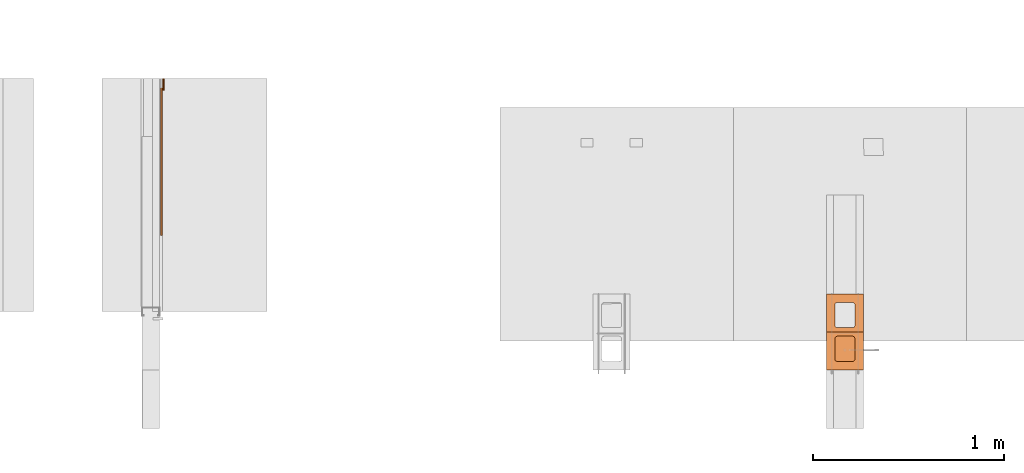
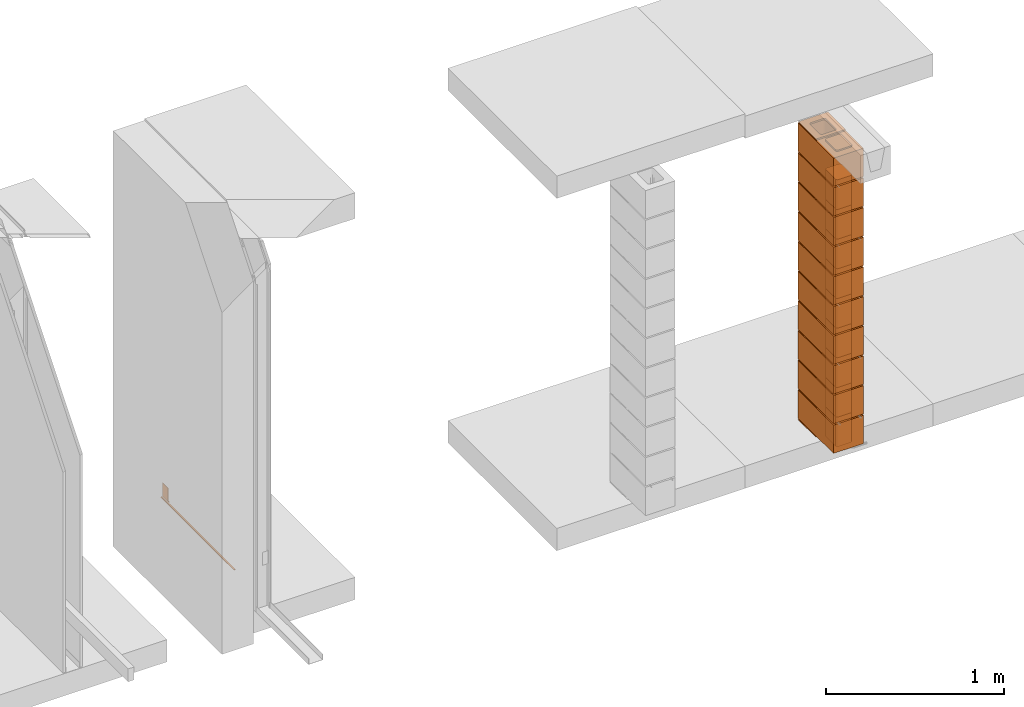
# One storey, part 44 of 64: 33 proxies.
"""IFC4 building model written with IfcOpenShell, lengths in feet."""

from ifc_helpers import new_model, entity, si_unit, converted_unit, frame, origin_with_axes, origin_2d_with_axis, place, context, subcontext, project, spatial, polyline, line, indexed_curve, outline, extrude, polygons, source, transform, mapped, material, type_object, type_shapes, element, save


model = new_model("IFC4")

# Units and contexts
model_context_1 = context("Model", 3, precision=1e-05, world=origin_with_axes())
plan_context = context("Plan", 2, precision=1e-05, world=origin_2d_with_axis())
model_context_2 = context("Model", 3, precision=1e-05, world=origin_with_axes())
context_of_model_1 = context(None, 3, precision=1e-05, world=origin_with_axes())
context_of_model_2 = context(None, 3, precision=1e-05, world=origin_with_axes())
body_context_1 = subcontext(model_context_1, "Body", "Model", "MODEL_VIEW")
body_context_2 = subcontext(model_context_2, "Body", "Model", "MODEL_VIEW")
ifc_project = project(units=[converted_unit("PLANEANGLEUNIT", "degree", entity("IfcReal", 0.0174532925199433), si_unit("PLANEANGLEUNIT", "RADIAN"), dimensions=[0, 0, 0, 0, 0, 0, 0]), converted_unit("AREAUNIT", "square foot", entity("IfcReal", 0.09290304), si_unit("AREAUNIT", "SQUARE_METRE"), dimensions=[2, 0, 0, 0, 0, 0, 0]), converted_unit("LENGTHUNIT", "foot", entity("IfcReal", 0.3048), si_unit("LENGTHUNIT", "METRE"), dimensions=[1, 0, 0, 0, 0, 0, 0]), converted_unit("VOLUMEUNIT", "cubic foot", entity("IfcReal", 0.0283168467116885), si_unit("VOLUMEUNIT", "CUBIC_METRE"), dimensions=[3, 0, 0, 0, 0, 0, 0])], contexts=[model_context_1, plan_context, context_of_model_1, context_of_model_2])

# Site, building, storey
site_placement = place(None, origin_with_axes())
site = spatial("IfcSite", under=ifc_project, at=site_placement)
building_placement = place(site_placement, origin_with_axes())
building = spatial("IfcBuilding", under=site, at=building_placement, Name="Building")
storey_placement = place(building_placement, origin_with_axes())
storey = spatial("IfcBuildingStorey", under=building, at=storey_placement, Name="Storey")

# Proxies
building_element_proxy_type_1 = type_object("IfcBuildingElementProxyType", PredefinedType="COMPLEX")
shared_shape_1 = source(origin_with_axes(), body_context_1, "Body", "SweptSolid", [
    extrude(outline(indexed_curve([(-0.317708352028228, -0.651041705777326), (0.317708352028228, -0.651041705777326), (0.317708352028228, 0.651041705777326), (-0.317708352028228, 0.651041705777326), (0.171874970041235, -0.114583378545255), (0.171874970041235, -0.463541685126898), (0.170455204220269, -0.47432586276938), (0.166292705639141, -0.484375053346939), (0.159671075466111, -0.493004429215208), (0.151041650709518, -0.499626059388238), (0.140992460131958, -0.50378860685769), (0.1302083313778, -0.505208323790332), (-0.1302083313778, -0.505208323790332), (-0.140992509020282, -0.50378860685769), (-0.151041699597842, -0.499626059388238), (-0.159671173242759, -0.493004429215208), (-0.166292705639141, -0.484375053346939), (-0.170455253108593, -0.47432586276938), (-0.171874970041235, -0.463541685126898), (-0.171874970041235, -0.114583378545255), (-0.170455253108593, -0.103799249791098), (-0.166292705639141, -0.0937500592135382), (-0.159671173242759, -0.0851205855686208), (-0.151041699597842, -0.0784989553955909), (-0.140992509020282, -0.0743364079261389), (-0.1302083313778, -0.0729166909934967), (0.1302083313778, -0.0729166909934967), (0.140992460131958, -0.0743364079261389), (0.151041650709518, -0.0784989553955909), (0.159671075466111, -0.0851205855686208), (0.166292705639141, -0.0937500592135382), (0.170455204220269, -0.103799249791098), (0.151041650709518, 0.0784989553955909), (0.140992460131958, 0.0743364079261389), (0.1302083313778, 0.0729166909934967), (-0.1302083313778, 0.0729166909934967), (-0.140992509020282, 0.0743364079261389), (-0.151041699597842, 0.0784989553955909), (-0.159671173242759, 0.0851204877919725), (-0.166292705639141, 0.0937499614368899), (-0.170455253108593, 0.10379915201445), (-0.171874970041235, 0.114583280768607), (-0.171874970041235, 0.46354158735025), (-0.170455253108593, 0.47432586276938), (-0.166292705639141, 0.484374955570291), (-0.159671173242759, 0.493004526991857), (-0.151041699597842, 0.499626059388238), (-0.140992509020282, 0.503788509081042), (-0.1302083313778, 0.505208323790332), (0.1302083313778, 0.505208323790332), (0.140992460131958, 0.503788509081042), (0.151041650709518, 0.499626059388238), (0.159671075466111, 0.493004526991857), (0.166292705639141, 0.484374955570291), (0.170455204220269, 0.47432586276938), (0.171874970041235, 0.46354158735025), (0.171874970041235, 0.114583280768607), (0.170455204220269, 0.10379915201445), (0.166292705639141, 0.0937499614368899), (0.159671075466111, 0.0851204877919725)], segments=[line(4, 3), line(3, 2), line(2, 1), line(1, 4)], self_intersect=False), holes=[indexed_curve([(-0.317708352028228, -0.651041705777326), (0.317708352028228, -0.651041705777326), (0.317708352028228, 0.651041705777326), (-0.317708352028228, 0.651041705777326), (0.171874970041235, -0.114583378545255), (0.171874970041235, -0.463541685126898), (0.170455204220269, -0.47432586276938), (0.166292705639141, -0.484375053346939), (0.159671075466111, -0.493004429215208), (0.151041650709518, -0.499626059388238), (0.140992460131958, -0.50378860685769), (0.1302083313778, -0.505208323790332), (-0.1302083313778, -0.505208323790332), (-0.140992509020282, -0.50378860685769), (-0.151041699597842, -0.499626059388238), (-0.159671173242759, -0.493004429215208), (-0.166292705639141, -0.484375053346939), (-0.170455253108593, -0.47432586276938), (-0.171874970041235, -0.463541685126898), (-0.171874970041235, -0.114583378545255), (-0.170455253108593, -0.103799249791098), (-0.166292705639141, -0.0937500592135382), (-0.159671173242759, -0.0851205855686208), (-0.151041699597842, -0.0784989553955909), (-0.140992509020282, -0.0743364079261389), (-0.1302083313778, -0.0729166909934967), (0.1302083313778, -0.0729166909934967), (0.140992460131958, -0.0743364079261389), (0.151041650709518, -0.0784989553955909), (0.159671075466111, -0.0851205855686208), (0.166292705639141, -0.0937500592135382), (0.170455204220269, -0.103799249791098), (0.151041650709518, 0.0784989553955909), (0.140992460131958, 0.0743364079261389), (0.1302083313778, 0.0729166909934967), (-0.1302083313778, 0.0729166909934967), (-0.140992509020282, 0.0743364079261389), (-0.151041699597842, 0.0784989553955909), (-0.159671173242759, 0.0851204877919725), (-0.166292705639141, 0.0937499614368899), (-0.170455253108593, 0.10379915201445), (-0.171874970041235, 0.114583280768607), (-0.171874970041235, 0.46354158735025), (-0.170455253108593, 0.47432586276938), (-0.166292705639141, 0.484374955570291), (-0.159671173242759, 0.493004526991857), (-0.151041699597842, 0.499626059388238), (-0.140992509020282, 0.503788509081042), (-0.1302083313778, 0.505208323790332), (0.1302083313778, 0.505208323790332), (0.140992460131958, 0.503788509081042), (0.151041650709518, 0.499626059388238), (0.159671075466111, 0.493004526991857), (0.166292705639141, 0.484374955570291), (0.170455204220269, 0.47432586276938), (0.171874970041235, 0.46354158735025), (0.171874970041235, 0.114583280768607), (0.170455204220269, 0.10379915201445), (0.166292705639141, 0.0937499614368899), (0.159671075466111, 0.0851204877919725)], segments=[line(20, 19), line(19, 18), line(18, 17), line(17, 16), line(16, 15), line(15, 14), line(14, 13), line(13, 12), line(12, 11), line(11, 10), line(10, 9), line(9, 8), line(8, 7), line(7, 6), line(6, 5), line(5, 32), line(32, 31), line(31, 30), line(30, 29), line(29, 28), line(28, 27), line(27, 26), line(26, 25), line(25, 24), line(24, 23), line(23, 22), line(22, 21), line(21, 20)], self_intersect=False), indexed_curve([(-0.317708352028228, -0.651041705777326), (0.317708352028228, -0.651041705777326), (0.317708352028228, 0.651041705777326), (-0.317708352028228, 0.651041705777326), (0.171874970041235, -0.114583378545255), (0.171874970041235, -0.463541685126898), (0.170455204220269, -0.47432586276938), (0.166292705639141, -0.484375053346939), (0.159671075466111, -0.493004429215208), (0.151041650709518, -0.499626059388238), (0.140992460131958, -0.50378860685769), (0.1302083313778, -0.505208323790332), (-0.1302083313778, -0.505208323790332), (-0.140992509020282, -0.50378860685769), (-0.151041699597842, -0.499626059388238), (-0.159671173242759, -0.493004429215208), (-0.166292705639141, -0.484375053346939), (-0.170455253108593, -0.47432586276938), (-0.171874970041235, -0.463541685126898), (-0.171874970041235, -0.114583378545255), (-0.170455253108593, -0.103799249791098), (-0.166292705639141, -0.0937500592135382), (-0.159671173242759, -0.0851205855686208), (-0.151041699597842, -0.0784989553955909), (-0.140992509020282, -0.0743364079261389), (-0.1302083313778, -0.0729166909934967), (0.1302083313778, -0.0729166909934967), (0.140992460131958, -0.0743364079261389), (0.151041650709518, -0.0784989553955909), (0.159671075466111, -0.0851205855686208), (0.166292705639141, -0.0937500592135382), (0.170455204220269, -0.103799249791098), (0.151041650709518, 0.0784989553955909), (0.140992460131958, 0.0743364079261389), (0.1302083313778, 0.0729166909934967), (-0.1302083313778, 0.0729166909934967), (-0.140992509020282, 0.0743364079261389), (-0.151041699597842, 0.0784989553955909), (-0.159671173242759, 0.0851204877919725), (-0.166292705639141, 0.0937499614368899), (-0.170455253108593, 0.10379915201445), (-0.171874970041235, 0.114583280768607), (-0.171874970041235, 0.46354158735025), (-0.170455253108593, 0.47432586276938), (-0.166292705639141, 0.484374955570291), (-0.159671173242759, 0.493004526991857), (-0.151041699597842, 0.499626059388238), (-0.140992509020282, 0.503788509081042), (-0.1302083313778, 0.505208323790332), (0.1302083313778, 0.505208323790332), (0.140992460131958, 0.503788509081042), (0.151041650709518, 0.499626059388238), (0.159671075466111, 0.493004526991857), (0.166292705639141, 0.484374955570291), (0.170455204220269, 0.47432586276938), (0.171874970041235, 0.46354158735025), (0.171874970041235, 0.114583280768607), (0.170455204220269, 0.10379915201445), (0.166292705639141, 0.0937499614368899), (0.159671075466111, 0.0851204877919725)], segments=[line(44, 43), line(43, 42), line(42, 41), line(41, 40), line(40, 39), line(39, 38), line(38, 37), line(37, 36), line(36, 35), line(35, 34), line(34, 33), line(33, 60), line(60, 59), line(59, 58), line(58, 57), line(57, 56), line(56, 55), line(55, 54), line(54, 53), line(53, 52), line(52, 51), line(51, 50), line(50, 49), line(49, 48), line(48, 47), line(47, 46), line(46, 45), line(45, 44)], self_intersect=False)]), frame((-0.651041608000678, -4.85461058579092e-05, 0.0), z_axis=(0.0, 0.0, 1.0), x_axis=(0.0, -1.0, 0.0)), (0.0, 0.0, 1.0), 0.635416715116103),
])
type_shapes(building_element_proxy_type_1, [shared_shape_1])
for number, where, z_axis, x_axis in (
    (1, (1419.09361511391, 2.30208313058368, 0.0312500003862178), (0.0, 0.0, 1.0), (7.54979012640431e-08, 0.999999999999997, 0.0)),
    (2, (1419.09361511391, 2.30208293503038, 0.697916710939933), (0.0, 0.0, 1.0), (1.94707183709394e-07, 0.999999999999981, 0.0)),
    (3, (1419.09361511391, 2.30208293503038, 1.36458341843813), (0.0, 0.0, 1.0), (1.94707183709394e-07, 0.999999999999981, 0.0)),
    (4, (1419.09361511391, 2.30208293503038, 2.03125022371297), (0.0, 0.0, 1.0), (1.94707183709394e-07, 0.999999999999981, 0.0)),
    (5, (1419.09361511391, 2.30208293503038, 2.69791683343452), (0.0, 0.0, 1.0), (1.94707183709394e-07, 0.999999999999981, 0.0)),
    (6, (1419.09361511391, 2.30208293503038, 3.36458324760277), (0.0, 0.0, 1.0), (1.94707183709394e-07, 0.999999999999981, 0.0)),
    (7, (1419.09361511391, 2.30208293503038, 4.03125024843091), (0.0, 0.0, 1.0), (1.94707183709394e-07, 0.999999999999981, 0.0)),
    (8, (1419.09361511391, 2.30208293503038, 4.69791685815245), (0.0, 0.0, 1.0), (1.94707183709394e-07, 0.999999999999981, 0.0)),
    (9, (1419.09361511391, 2.30208293503038, 5.364583467874), (0.0, 0.0, 1.0), (1.94707183709394e-07, 0.999999999999981, 0.0)),
    (10, (1419.09361511391, 2.30208293503038, 6.03125007759555), (0.0, 0.0, 1.0), (1.94707183709394e-07, 0.999999999999981, 0.0)),
):
    element("IfcBuildingElementProxy", number, at=place(storey_placement, frame(where, z_axis=z_axis, x_axis=x_axis)), inside=storey, type_object=building_element_proxy_type_1, context=body_context_1, shape_type="MappedRepresentation", body=[
        mapped(shared_shape_1, transform((0.0, 0.0, 0.0), x_axis=(1.0, 0.0, 0.0), y_axis=(0.0, 1.0, 0.0), z_axis=(0.0, 0.0, 1.0), scale=1.0)),
    ])
building_element_proxy_type_2 = type_object("IfcBuildingElementProxyType", PredefinedType="COMPLEX")
shared_shape_2 = source(origin_with_axes(), body_context_1, "Body", "Tessellation", [
    polygons([(-0.151415750384331, -0.151090204715729, -3.05552028123657e-09), (-9.77766489995702e-08, -0.31775689125061, -3.05552028123657e-09), (-0.158037275075912, -0.159719616174698, -3.05552028123657e-09), (-0.147253289818764, -0.14104101061821, -3.05552028123657e-09), (-0.145833477377892, -0.130256876349449, -3.05552028123657e-09), (-9.77766489995702e-08, 0.317659795284271, -3.05552028123657e-09), (-0.176715940237045, 0.170406714081764, -3.05552028123657e-09), (-0.187500223517418, 0.171826422214508, -3.05552028123657e-09), (-0.166666850447655, 0.16624416410923, -3.05552028123657e-09), (-0.158037275075912, 0.159622624516487, -3.05552028123657e-09), (-0.151415750384331, 0.150993153452873, -3.05552028123657e-09), (-0.147253289818764, 0.140943959355354, -3.05552028123657e-09), (-0.145833477377892, 0.13015978038311, -3.05552028123657e-09), (-0.57812511920929, 0.13015978038311, -3.05552028123657e-09), (-0.57812511920929, -0.130256876349449, -3.05552028123657e-09), (-0.57812511920929, 0.13015978038311, -0.0312500037252903), (-0.57812511920929, -0.130256876349449, -0.0312500037252903), (-0.187500223517418, 0.171826422214508, -0.0312500037252903), (-0.176715940237045, 0.170406714081764, -0.0312500037252903), (-0.151415750384331, 0.150993153452873, -0.0312500037252903), (-0.158037275075912, 0.159622624516487, -0.0312500037252903), (-0.166666850447655, 0.16624416410923, -0.0312500037252903), (-0.57254284620285, 0.150993153452873, -0.0312500037252903), (-0.57254284620285, 0.150993153452873, -3.05552028123657e-09), (-0.576705396175385, 0.140943959355354, -0.0312500037252903), (-0.576705396175385, 0.140943959355354, -3.05552028123657e-09), (-0.536458551883698, -0.171923518180847, -0.0312500037252903), (-0.536458551883698, -0.171923518180847, -3.05552028123657e-09), (-0.547242641448975, -0.170503750443459, -3.05552028123657e-09), (-0.547242641448975, -0.170503750443459, -0.0312500037252903), (-0.187500223517418, -0.171923518180847, -3.05552028123657e-09), (-0.187500223517418, -0.171923518180847, -0.0312500037252903), (-9.77766489995702e-08, 0.311301797628403, -0.0156250037252903), (-0.112195670604706, 0.311415702104568, -0.0178805738687515), (-9.77766489995702e-08, 0.312040388584137, -0.021326893940568), (-0.651041805744171, 0.312040388584137, -0.0099231107160449), (-0.525620222091675, 0.311301797628403, -0.0156250055879354), (-0.651041805744171, 0.311301797628403, -0.0156250037252903), (-0.14959417283535, 0.317659795284271, -3.05552028123657e-09), (-9.77766489995702e-08, 0.314207404851913, -0.00459759868681431), (-0.651041805744171, 0.317659795284271, -3.05552028123657e-09), (-0.501447737216949, 0.317659795284271, -3.05552028123657e-09), (-0.651041805744171, 0.314207404851913, -0.00459759868681431), (-9.77766489995702e-08, -0.314304441213608, -0.00459759868681431), (-0.112195670604706, -0.31151282787323, -0.0133694317191839), (-0.14959417283535, -0.31775689125061, -3.05552028123657e-09), (-9.77766489995702e-08, 0.314207404851913, -0.0266524087637663), (-0.14959417283535, 0.317659795284271, -0.0312500037252903), (-0.651041805744171, 0.314207404851913, -0.0266524087637663), (-0.501447856426239, 0.317659795284271, -0.0312500037252903), (-0.651041805744171, 0.317659795284271, -0.0312500037252903), (-9.77766489995702e-08, 0.317659795284271, -0.0312500037252903), (-9.77766489995702e-08, 0.312040388584137, -0.0099231107160449), (-0.651041805744171, 0.312040388584137, -0.021326893940568), (-0.14959417283535, -0.31775689125061, -0.0312500037252903), (-0.158037275075912, -0.159719616174698, -0.0312500037252903), (-9.77766489995702e-08, -0.31775689125061, -0.0312500037252903), (-0.151415750384331, -0.151090204715729, -0.0312500037252903), (-0.166666850447655, -0.166341260075569, -0.0312500037252903), (-0.176715940237045, -0.170503750443459, -0.0312500037252903), (-0.147253289818764, -0.14104101061821, -0.0312500037252903), (-0.145833477377892, -0.130256876349449, -0.0312500037252903), (-0.536458551883698, 0.171826422214508, -3.05552028123657e-09), (-9.77766489995702e-08, -0.314304441213608, -0.0266524087637663), (-0.651041805744171, -0.31775689125061, -0.0312500037252903), (-0.557291865348816, -0.166341260075569, -0.0312500037252903), (-0.565921306610107, -0.159719616174698, -0.0312500037252903), (-0.57254284620285, -0.151090204715729, -0.0312500037252903), (-0.576705396175385, -0.14104101061821, -0.0312500037252903), (-0.501447737216949, -0.31775689125061, -3.05552028123657e-09), (-0.547242641448975, 0.170406714081764, -3.05552028123657e-09), (-0.557291865348816, 0.16624416410923, -0.0312500037252903), (-0.547242641448975, 0.170406714081764, -0.0312500037252903), (-0.565921306610107, 0.159622624516487, -0.0312500037252903), (-9.77766489995702e-08, -0.311398863792419, -0.0156250037252903), (-9.77766489995702e-08, -0.312137424945831, -0.0099231107160449), (-0.651041805744171, -0.312137424945831, -0.021326893940568), (-0.525620222091675, -0.311398863792419, -0.0156250018626451), (-0.651041805744171, -0.311398863792419, -0.0156250037252903), (-0.501447737216949, -0.31775689125061, -0.0312500037252903), (-0.651041805744171, -0.314304441213608, -0.0266524087637663), (-0.651041805744171, -0.314304441213608, -0.00459759868681431), (-0.651041805744171, -0.31775689125061, -3.05552028123657e-09), (-9.77766489995702e-08, -0.312137424945831, -0.021326893940568), (-0.651041805744171, -0.312137424945831, -0.0099231107160449), (-0.145833477377892, 0.13015978038311, -0.0312500037252903), (-0.147253289818764, 0.140943959355354, -0.0312500037252903), (-0.536458551883698, 0.171826422214508, -0.0312500037252903), (-0.557291865348816, -0.166341260075569, -3.05552028123657e-09), (-0.176715940237045, -0.170503750443459, -3.05552028123657e-09), (-0.166666850447655, -0.166341260075569, -3.05552028123657e-09), (-0.576705396175385, -0.14104101061821, -3.05552028123657e-09), (-0.565921306610107, -0.159719616174698, -3.05552028123657e-09), (-0.57254284620285, -0.151090204715729, -3.05552028123657e-09), (-0.565921306610107, 0.159622624516487, -3.05552028123657e-09), (-0.557291865348816, 0.16624416410923, -3.05552028123657e-09)], [[[1, 3, 2]], [[4, 1, 2]], [[5, 4, 2]], [[6, 8, 7]], [[7, 9, 6]], [[9, 10, 6]], [[6, 10, 11]], [[6, 11, 12]], [[6, 12, 13]], [[6, 13, 5]], [[6, 5, 2]], [[20, 11, 10, 21]], [[63, 88, 18, 8]], [[7, 19, 22, 9]], [[95, 74, 72, 96]], [[71, 73, 88, 63]], [[61, 4, 5, 62]], [[17, 15, 92, 69]], [[23, 24, 26, 25]], [[33, 35, 34]], [[37, 38, 36]], [[6, 40, 39]], [[42, 43, 41]], [[44, 46, 45]], [[47, 48, 34]], [[50, 51, 49]], [[47, 52, 48]], [[53, 33, 34]], [[37, 36, 43]], [[37, 54, 38]], [[56, 57, 55]], [[58, 57, 56]], [[59, 56, 55]], [[60, 59, 55]], [[61, 57, 58]], [[62, 57, 61]], [[32, 60, 55]], [[47, 35, 84, 64]], [[52, 57, 62]], [[65, 81, 49, 51]], [[66, 30, 65]], [[67, 66, 65]], [[68, 67, 65]], [[69, 68, 65]], [[17, 69, 65]], [[27, 32, 55, 80]], [[41, 43, 82, 83]], [[51, 73, 72]], [[51, 72, 74]], [[51, 74, 23]], [[51, 23, 25]], [[16, 51, 25]], [[17, 51, 16]], [[65, 51, 17]], [[75, 76, 45]], [[78, 79, 77]], [[57, 64, 55]], [[80, 81, 65]], [[70, 83, 82]], [[44, 2, 46]], [[84, 75, 45]], [[78, 77, 81]], [[78, 85, 79]], [[3, 56, 59, 91]], [[14, 15, 17, 16]], [[27, 28, 31, 32]], [[86, 13, 12, 87]], [[28, 27, 30, 29]], [[8, 18, 19, 7]], [[90, 60, 32, 31]], [[89, 93, 83]], [[94, 83, 93]], [[28, 29, 83, 70]], [[29, 89, 83]], [[92, 83, 94]], [[15, 83, 92]], [[39, 42, 63, 8]], [[90, 31, 46]], [[41, 14, 26]], [[41, 26, 24]], [[41, 24, 95]], [[41, 95, 96]], [[41, 96, 71]], [[41, 15, 14]], [[41, 83, 15]], [[91, 90, 46]], [[3, 46, 2]], [[3, 91, 46]], [[51, 50, 88, 73]], [[6, 39, 8]], [[52, 62, 86]], [[52, 86, 87]], [[52, 87, 20]], [[21, 52, 20]], [[48, 21, 22]], [[48, 22, 19]], [[48, 19, 18]], [[48, 52, 21]], [[58, 1, 4, 61]], [[89, 66, 67, 93]], [[68, 94, 93, 67]], [[52, 47, 64, 57]], [[53, 40, 44, 76]], [[75, 84, 35, 33]], [[2, 44, 40, 6]], [[43, 36, 85, 82]], [[79, 85, 36, 38]], [[88, 50, 48, 18]], [[80, 65, 30, 27]], [[87, 12, 11, 20]], [[78, 46, 70]], [[70, 82, 78]], [[78, 82, 85]], [[78, 45, 46]], [[76, 44, 45]], [[37, 48, 50]], [[50, 49, 37]], [[37, 49, 54]], [[37, 34, 48]], [[35, 47, 34]], [[42, 37, 43]], [[39, 37, 42]], [[39, 40, 34]], [[40, 53, 34]], [[34, 37, 39]], [[80, 78, 81]], [[55, 78, 80]], [[55, 64, 45]], [[64, 84, 45]], [[45, 78, 55]], [[91, 59, 60, 90]], [[54, 49, 81, 77]], [[38, 54, 77, 79]], [[86, 62, 5, 13]], [[96, 72, 73, 71]], [[25, 26, 14, 16]], [[56, 3, 1, 58]], [[74, 95, 24, 23]], [[28, 70, 46, 31]], [[71, 63, 42, 41]], [[33, 53, 76, 75]], [[29, 30, 66, 89]], [[69, 92, 94, 68]], [[9, 22, 21, 10]]]),
])
type_shapes(building_element_proxy_type_2, [shared_shape_2])
for number, where, z_axis, x_axis in (
    (11, (1419.09361511391, 2.30208332613697, 0.031250003441738), (0.0, 0.0, 1.0), (7.54979012640431e-08, 0.999999999999997, 0.0)),
    (12, (1419.09361511391, 2.30208313058368, 0.697916710939933), (0.0, 0.0, 1.0), (1.94707183709394e-07, 0.999999999999981, 0.0)),
    (13, (1419.09361511391, 2.30208313058368, 1.36458341843813), (0.0, 0.0, 1.0), (1.94707183709394e-07, 0.999999999999981, 0.0)),
    (14, (1419.09361511391, 2.30208313058368, 2.03125022371297), (0.0, 0.0, 1.0), (1.94707183709394e-07, 0.999999999999981, 0.0)),
    (15, (1419.09361511391, 2.30208313058368, 2.69791683343452), (0.0, 0.0, 1.0), (1.94707183709394e-07, 0.999999999999981, 0.0)),
    (16, (1419.09361511391, 2.30208313058368, 3.36458363870936), (0.0, 0.0, 1.0), (1.94707183709394e-07, 0.999999999999981, 0.0)),
    (17, (1419.09361511391, 2.30208313058368, 4.0312506395375), (0.0, 0.0, 1.0), (1.94707183709394e-07, 0.999999999999981, 0.0)),
    (18, (1419.09361511391, 2.30208313058368, 4.69791685815245), (0.0, 0.0, 1.0), (1.94707183709394e-07, 0.999999999999981, 0.0)),
    (19, (1419.09361511391, 2.30208313058368, 5.36458385898059), (0.0, 0.0, 1.0), (1.94707183709394e-07, 0.999999999999981, 0.0)),
    (20, (1419.09361511391, 2.30208313058368, 6.03125007759555), (0.0, 0.0, 1.0), (1.94707183709394e-07, 0.999999999999981, 0.0)),
    (21, (1419.09361511391, 2.30208313058368, 6.69791707842369), (0.0, 0.0, 1.0), (1.94707183709394e-07, 0.999999999999981, 0.0)),
):
    element("IfcBuildingElementProxy", number, at=place(storey_placement, frame(where, z_axis=z_axis, x_axis=x_axis)), inside=storey, type_object=building_element_proxy_type_2, context=body_context_1, shape_type="MappedRepresentation", body=[
        mapped(shared_shape_2, transform((0.0, 0.0, 0.0), x_axis=(1.0, 0.0, 0.0), y_axis=(0.0, 1.0, 0.0), z_axis=(0.0, 0.0, 1.0), scale=1.0)),
    ])
building_element_proxy_type_3 = type_object("IfcBuildingElementProxyType", Name="Core_Fill_8in", PredefinedType="COMPLEX")
shared_shape_3 = source(origin_with_axes(), body_context_1, "Body", "SweptSolid", [
    extrude(outline(polyline([(0.259134248681269, -1.22220810316992e-08), (0.258783548288145, 0.0108715899660206), (0.255631180260125, 0.0212817841510134), (0.249891788784287, 0.0305214696356005), (0.241956358232836, 0.0379609159167044), (-0.041594876714657, 0.241358356252117), (-0.0511852381482055, 0.246490456965652), (-0.0617770769014915, 0.248965550595381), (-0.0726485690908639, 0.248614947978906), (-0.0830589404960317, 0.2454625066184), (-0.0922986626468618, 0.239723115142562), (-0.0997380661506822, 0.231787733479435), (-0.251527225447139, 0.0201822246309966), (-0.256659350604836, 0.0105919243078532), (-0.259134370902079, 9.77766482535935e-08), (-0.25878371939728, -0.0108714555231292), (-0.255631229148449, -0.0212818452614186), (-0.249891837672612, -0.0305215063018436), (-0.241956529341971, -0.0379609159167044), (0.0415947850490492, -0.241358380696279), (0.0511851587046788, -0.246490530298138), (0.0617769913469243, -0.248965550595381), (0.0726485018694182, -0.24861487464642), (0.0830587999420998, -0.245462408841751), (0.092298534315011, -0.239723066254238), (0.0997378767084262, -0.231787757923597), (0.251527029893843, -0.0201822490751587), (0.256659252828188, -0.0105918754195291), (0.259134248681269, -1.22220810316992e-08)])), frame((-0.940104188725079, -4.85716958400693e-05, 0.0), z_axis=(0.0, 0.0, -1.0), x_axis=(-0.81256514787674, 0.582870364189148, 0.0)), (-1.7679644415125e-08, -3.70824935203018e-08, -1.0), 0.666666714702408),
])
type_shapes(building_element_proxy_type_3, [shared_shape_3])
for number, where, z_axis, x_axis in (
    (22, (1419.09361511391, 2.30208293503038, 0.0312500003862178), (0.0, 0.0, 1.0), (1.94707183709394e-07, 0.999999999999981, 0.0)),
    (23, (1419.09361511391, 2.30208273947708, 0.697916710939933), (0.0, 0.0, 1.0), (3.13916473260163e-07, 0.999999999999951, 0.0)),
    (24, (1419.09361511391, 2.30208273947708, 1.36458341843813), (0.0, 0.0, 1.0), (3.13916473260163e-07, 0.999999999999951, 0.0)),
    (25, (1419.09361511391, 2.30208273947708, 2.03125022371297), (0.0, 0.0, 1.0), (3.13916473260163e-07, 0.999999999999951, 0.0)),
    (26, (1419.09361511391, 2.30208273947708, 2.69791683343452), (0.0, 0.0, 1.0), (3.13916473260163e-07, 0.999999999999951, 0.0)),
    (27, (1419.09361511391, 2.30208273947708, 3.36458324760277), (0.0, 0.0, 1.0), (3.13916473260163e-07, 0.999999999999951, 0.0)),
    (28, (1419.09361511391, 2.30208273947708, 4.03125024843091), (0.0, 0.0, 1.0), (3.13916473260163e-07, 0.999999999999951, 0.0)),
    (29, (1419.09361511391, 2.30208273947708, 4.69791685815245), (0.0, 0.0, 1.0), (3.13916473260163e-07, 0.999999999999951, 0.0)),
    (30, (1419.09361511391, 2.30208273947708, 5.364583467874), (0.0, 0.0, 1.0), (3.13916473260163e-07, 0.999999999999951, 0.0)),
    (31, (1419.09361511391, 2.30208273947708, 6.03125007759555), (0.0, 0.0, 1.0), (3.13916473260163e-07, 0.999999999999951, 0.0)),
):
    element("IfcBuildingElementProxy", number, at=place(storey_placement, frame(where, z_axis=z_axis, x_axis=x_axis)), inside=storey, type_object=building_element_proxy_type_3, context=body_context_1, shape_type="MappedRepresentation", body=[
        mapped(shared_shape_3, transform((0.0, 0.0, 0.0), x_axis=(1.0, 0.0, 0.0), y_axis=(0.0, 1.0, 0.0), z_axis=(0.0, 0.0, 1.0), scale=1.0)),
    ])
ifc_material_1 = material(Name="ACOUSTICAL SEALANT OR FIRE SEALANT, IF RATED WALL", Category="sealant")
proxy_1_placement = place(storey_placement, frame((1407.36006689197, 5.99999987860051, 0.0), z_axis=(4.37113882867379e-08, -0.999999999999999, -8.51092183247426e-15), x_axis=(1.94707183709394e-07, 0.0, 0.999999999999981)))
element("IfcBuildingElementProxy", 32, at=proxy_1_placement, inside=storey, material=ifc_material_1, Name="Generic Models 553:Generic Models 1", PredefinedType="COMPLEX", context=body_context_2, shape_type="SweptSolid", body=[
    extrude(outline(polyline([(0.0175297320783725, -9.54850080601499e-10), (-0.00760452458243866, 0.0185696432596742), (-0.0101125689426295, 0.00747134591259668), (-0.0199842865009281, 0.00181346750552974), (0.00514996939600296, -0.0167561767089946), (0.0150216877181816, -0.0110982973470775), (0.0175297320783725, -9.54850080601499e-10)])), frame((0.0104166718879397, -0.0185779741356575, -2.21466746225091e-09), z_axis=(-3.55149124085102e-14, 1.19209261129072e-07, -1.0), x_axis=(0.594228386878967, 0.804296314716339, 9.58795709493643e-08)), (5.34579103206312e-10, -4.63880350798362e-10, -0.999999940395355), 2.69194742001661),
])
ifc_material_2 = material(Name="WALL BASE AS SCHEDULED")
proxy_2_placement = place(storey_placement, frame((1407.39581090572, 5.99999987860051, 0.0), z_axis=(4.37113882867379e-08, -0.999999999999999, -8.51092183247426e-15), x_axis=(1.94707183709394e-07, 0.0, 0.999999999999981)))
element("IfcBuildingElementProxy", 33, at=proxy_2_placement, inside=storey, material=ifc_material_2, Name="Generic Models 563:Generic Models 1", PredefinedType="COMPLEX", context=body_context_2, shape_type="SweptSolid", body=[
    extrude(outline(polyline([(0.097109230963655, 5.729096841145e-10), (0.105915723119195, -0.00895523717333599), (0.114232641485889, -0.00268339837615298), (0.103519474134201, 0.00821070924640836), (0.0903517462489173, 0.0159608354801777), (0.0756268213525062, 0.0200388275375321), (0.060348162852873, 0.0201667713372922), (-0.220178443146503, -0.0143780194594478), (-0.219742090409509, -0.0179214574142391), (-0.217160151347401, -0.0224812561279441), (-0.212110158574237, -0.0238798196938407), (0.0616212820345805, 0.00982819625550485), (0.0741807413910787, 0.00972302448434701), (0.0862850137837133, 0.0063708082441573), (0.097109230963655, 5.729096841145e-10)])), frame((0.113048285167674, -0.0126398409279234, -1.50679009951663e-09), z_axis=(-3.31246802990487e-14, 1.19209303761636e-07, -1.0), x_axis=(-0.992503106594086, -0.122219651937485, -1.45696859021882e-08)), (0.0185199864208698, -0.00323581066913903, -0.999823212623596), 0.209783633194424),
])

save(model, "model.ifc")
